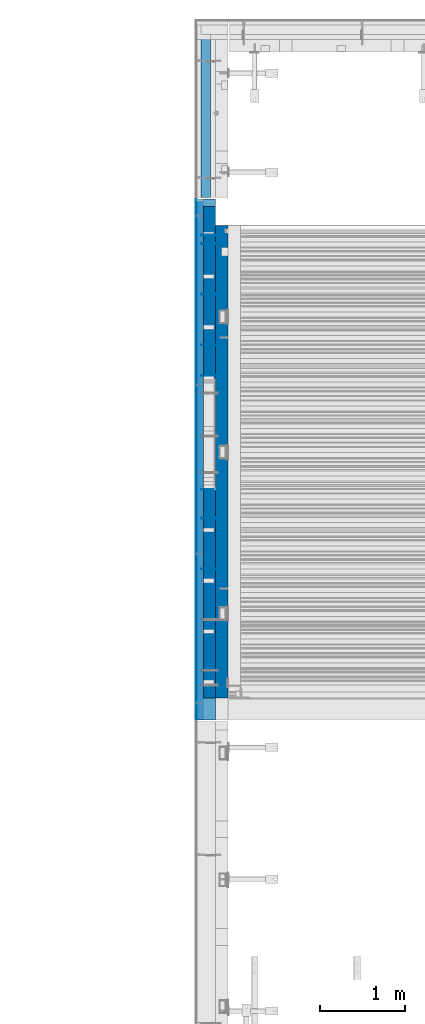
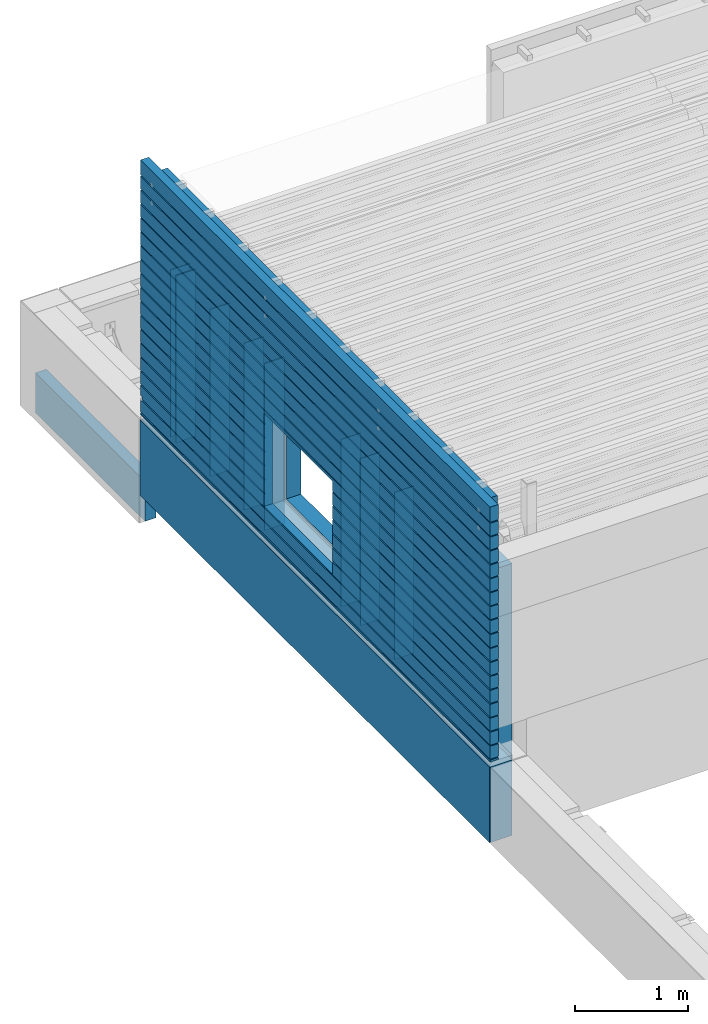
# One storey, part 78 of 153: 14 walls, 2 elements without a shape of their own.
"""IFC2X3 building model written with IfcOpenShell, lengths in millimetres."""

from ifc_helpers import new_model, si_unit, frame, origin_with_axes, place, context, subcontext, project, spatial, faceted_brep, material, type_object, element, aggregate, save


model = new_model("IFC2X3")

# Units and contexts
model_context = context("Model", 3, precision=1e-05, world=origin_with_axes())
body_context = subcontext(model_context, "Body", "Model", "MODEL_VIEW")
ifc_project = project(units=[si_unit("LENGTHUNIT", "METRE", prefix="MILLI"), si_unit("AREAUNIT", "SQUARE_METRE"), si_unit("VOLUMEUNIT", "CUBIC_METRE"), si_unit("MASSUNIT", "GRAM", prefix="KILO"), si_unit("TIMEUNIT", "SECOND"), si_unit("PLANEANGLEUNIT", "RADIAN"), si_unit("SOLIDANGLEUNIT", "STERADIAN"), si_unit("THERMODYNAMICTEMPERATUREUNIT", "DEGREE_CELSIUS"), si_unit("LUMINOUSINTENSITYUNIT", "LUMEN")], contexts=[model_context])

# Site, building, storey
site_placement = place(None, origin_with_axes())
site = spatial("IfcSite", under=ifc_project, at=site_placement, CompositionType="ELEMENT")
building_placement = place(site_placement, origin_with_axes())
building = spatial("IfcBuilding", under=site, at=building_placement, CompositionType="ELEMENT")
storey_placement = place(building_placement, origin_with_axes())
storey = spatial("IfcBuildingStorey", under=building, at=storey_placement, Name="8", CompositionType="ELEMENT", Elevation=0.0)

# Assembly, walls
assembly_1_placement = place(storey_placement, origin_with_axes())
assembly_1 = element("IfcElementAssembly", 1, at=assembly_1_placement, inside=storey, AssemblyPlace="NOTDEFINED", PredefinedType="REINFORCEMENT_UNIT")
ifc_material_1 = material(Name="Undefined")
wall_type_1 = type_object("IfcWallType", PredefinedType="NOTDEFINED")
wall_1_placement = place(assembly_1_placement, frame((7880.0, 18794.39, 104525.0), z_axis=(0.0, 0.0, 1.0), x_axis=(-1.0, 3.00000001838171e-08, 0.0)))
wall_1 = element("IfcWall", 2, at=wall_1_placement, type_object=wall_type_1, material=ifc_material_1, Name="(PD)", context=body_context, shape_type="Brep", body=[
    faceted_brep([(0.0, 5.0, -900.0), (0.0, 5.0, 900.0), (200.0, 5.0, 900.0), (200.0, 5.0, -900.0), (0.0, -5.0, 900.0), (200.0, -5.0, 900.0), (0.0, -5.0, -900.0), (200.0, -5.0, -900.0)], [[[0, 1, 2, 3]], [[1, 4, 5, 2]], [[4, 6, 7, 5]], [[6, 0, 3, 7]], [[5, 7, 3, 2]], [[6, 4, 1, 0]]]),
])
wall_2_placement = place(assembly_1_placement, frame((7880.0, 19154.39, 104525.0), z_axis=(0.0, 0.0, 1.0), x_axis=(-1.0, 3.00000001838171e-08, 0.0)))
wall_2 = element("IfcWall", 3, at=wall_2_placement, type_object=wall_type_1, material=ifc_material_1, Name="(PD)", context=body_context, shape_type="Brep", body=[
    faceted_brep([(0.0, 5.0, -900.0), (0.0, 5.0, 900.0), (200.0, 5.0, 900.0), (200.0, 5.0, -900.0), (0.0, -5.0, 900.0), (200.0, -5.0, 900.0), (0.0, -5.0, -900.0), (200.0, -5.0, -900.0)], [[[0, 1, 2, 3]], [[1, 4, 5, 2]], [[4, 6, 7, 5]], [[6, 0, 3, 7]], [[5, 7, 3, 2]], [[6, 4, 1, 0]]]),
])
wall_3_placement = place(assembly_1_placement, frame((7880.0, 19754.39, 104525.0), z_axis=(0.0, 0.0, 1.0), x_axis=(-1.0, 3.00000001838171e-08, 0.0)))
wall_3 = element("IfcWall", 4, at=wall_3_placement, type_object=wall_type_1, material=ifc_material_1, Name="(PD)", context=body_context, shape_type="Brep", body=[
    faceted_brep([(0.0, 5.0, -900.0), (0.0, 5.0, 900.0), (200.0, 5.0, 900.0), (200.0, 5.0, -900.0), (0.0, -5.0, 900.0), (200.0, -5.0, 900.0), (0.0, -5.0, -900.0), (200.0, -5.0, -900.0)], [[[0, 1, 2, 3]], [[1, 4, 5, 2]], [[4, 6, 7, 5]], [[6, 0, 3, 7]], [[5, 7, 3, 2]], [[6, 4, 1, 0]]]),
])
wall_4_placement = place(assembly_1_placement, frame((7880.0, 20454.39, 104525.0), z_axis=(0.0, 0.0, 1.0), x_axis=(-1.0, 3.00000001838171e-08, 0.0)))
wall_4 = element("IfcWall", 5, at=wall_4_placement, type_object=wall_type_1, material=ifc_material_1, Name="(PD)", context=body_context, shape_type="Brep", body=[
    faceted_brep([(0.0, 5.0, -900.0), (0.0, 5.0, 900.0), (200.0, 5.0, 900.0), (200.0, 5.0, -900.0), (0.0, -5.0, 900.0), (200.0, -5.0, 900.0), (0.0, -5.0, -900.0), (200.0, -5.0, -900.0)], [[[0, 1, 2, 3]], [[1, 4, 5, 2]], [[4, 6, 7, 5]], [[6, 0, 3, 7]], [[5, 7, 3, 2]], [[6, 4, 1, 0]]]),
])
wall_5_placement = place(assembly_1_placement, frame((7880.0, 16504.39, 104525.0), z_axis=(0.0, 0.0, 1.0), x_axis=(-1.0, 3.00000001838171e-08, 0.0)))
wall_5 = element("IfcWall", 6, at=wall_5_placement, type_object=wall_type_1, material=ifc_material_1, Name="(PD)", context=body_context, shape_type="Brep", body=[
    faceted_brep([(0.0, 5.0, -900.0), (0.0, 5.0, 900.0), (200.0, 5.0, 900.0), (200.0, 5.0, -900.0), (0.0, -5.0, 900.0), (200.0, -5.0, 900.0), (0.0, -5.0, -900.0), (200.0, -5.0, -900.0)], [[[0, 1, 2, 3]], [[1, 4, 5, 2]], [[4, 6, 7, 5]], [[6, 0, 3, 7]], [[5, 7, 3, 2]], [[6, 4, 1, 0]]]),
])
wall_6_placement = place(assembly_1_placement, frame((7880.0, 20354.39, 104525.0), z_axis=(0.0, 0.0, 1.0), x_axis=(-1.0, 3.00000001838171e-08, 0.0)))
wall_6 = element("IfcWall", 7, at=wall_6_placement, type_object=wall_type_1, material=ifc_material_1, Name="(PD)", context=body_context, shape_type="Brep", body=[
    faceted_brep([(0.0, 5.0, -900.0), (0.0, 5.0, 900.0), (200.0, 5.0, 900.0), (200.0, 5.0, -900.0), (0.0, -5.0, 900.0), (200.0, -5.0, 900.0), (0.0, -5.0, -900.0), (200.0, -5.0, -900.0)], [[[0, 1, 2, 3]], [[1, 4, 5, 2]], [[4, 6, 7, 5]], [[6, 0, 3, 7]], [[5, 7, 3, 2]], [[6, 4, 1, 0]]]),
])
wall_7_placement = place(assembly_1_placement, frame((7880.0, 17444.39, 104525.0), z_axis=(0.0, 0.0, 1.0), x_axis=(-1.0, 3.00000001838171e-08, 0.0)))
wall_7 = element("IfcWall", 8, at=wall_7_placement, type_object=wall_type_1, material=ifc_material_1, Name="(PD)", context=body_context, shape_type="Brep", body=[
    faceted_brep([(0.0, 5.0, -900.0), (0.0, 5.0, 900.0), (200.0, 5.0, 900.0), (200.0, 5.0, -900.0), (0.0, -5.0, 900.0), (200.0, -5.0, 900.0), (0.0, -5.0, -900.0), (200.0, -5.0, -900.0)], [[[0, 1, 2, 3]], [[1, 4, 5, 2]], [[4, 6, 7, 5]], [[6, 0, 3, 7]], [[5, 7, 3, 2]], [[6, 4, 1, 0]]]),
])
wall_8_placement = place(assembly_1_placement, frame((7880.0, 17104.39, 104525.0), z_axis=(0.0, 0.0, 1.0), x_axis=(-1.0, 3.00000001838171e-08, 0.0)))
wall_8 = element("IfcWall", 9, at=wall_8_placement, type_object=wall_type_1, material=ifc_material_1, Name="(PD)", context=body_context, shape_type="Brep", body=[
    faceted_brep([(0.0, 5.0, -900.0), (0.0, 5.0, 900.0), (200.0, 5.0, 900.0), (200.0, 5.0, -900.0), (0.0, -5.0, 900.0), (200.0, -5.0, 900.0), (0.0, -5.0, -900.0), (200.0, -5.0, -900.0)], [[[0, 1, 2, 3]], [[1, 4, 5, 2]], [[4, 6, 7, 5]], [[6, 0, 3, 7]], [[5, 7, 3, 2]], [[6, 4, 1, 0]]]),
])

# Assembly, wall
assembly_2_placement = place(storey_placement, origin_with_axes())
assembly_2 = element("IfcElementAssembly", 10, at=assembly_2_placement, inside=storey, AssemblyPlace="NOTDEFINED", PredefinedType="REINFORCEMENT_UNIT")
ifc_material_2 = material(Name="CONCRETE/C25/30")
wall_type_2 = type_object("IfcWallType", PredefinedType="NOTDEFINED")
wall_9_placement = place(assembly_2_placement, frame((7734.99893035865, 22830.0018973893, 102660.0), z_axis=(0.0, 0.0, 1.0), x_axis=(0.0, -1.0, 0.0)))
wall_9 = element("IfcWall", 11, at=wall_9_placement, type_object=wall_type_2, material=ifc_material_2, context=body_context, shape_type="Brep", body=[
    faceted_brep([(9.09494701772928e-13, 55.0, -215.0), (9.09494701772928e-13, 55.0, 215.0), (1930.00200932268, 55.0000000000009, 215.0), (1930.00200932268, 55.0000000000009, -215.0), (0.0, -55.0, 215.0), (1930.00200932269, -55.0, 215.0), (0.0, -55.0, -215.0), (1930.00200932269, -55.0, -215.0)], [[[0, 1, 2, 3]], [[1, 4, 5, 2]], [[4, 6, 7, 5]], [[6, 0, 3, 7]], [[5, 7, 3, 2]], [[6, 4, 1, 0]]]),
])
aggregate(assembly_2, [wall_9])

# Wall
ifc_material_3 = material()
wall_type_3 = type_object("IfcWallType", PredefinedType="NOTDEFINED")
wall_10_placement = place(assembly_1_placement, frame((7740.0, 14717.03, 103162.5), z_axis=(0.0, 0.0, 1.0), x_axis=(0.0, 1.0, 0.0)))
wall_10 = element("IfcWall", 12, at=wall_10_placement, type_object=wall_type_3, material=ifc_material_3, context=body_context, shape_type="Brep", body=[
    faceted_brep([(0.0, 110.0, -407.5), (0.0, 110.0, 407.5), (6167.97, 110.0, 407.5), (6167.97, 110.0, -407.5), (0.0, -110.0, 407.5), (6167.97, -110.0, 407.5), (0.0, -110.0, -407.5), (6167.97, -110.0, -407.5)], [[[0, 1, 2, 3]], [[1, 4, 5, 2]], [[4, 6, 7, 5]], [[6, 0, 3, 7]], [[5, 7, 3, 2]], [[6, 4, 1, 0]]]),
])

ifc_material_4 = material()
wall_type_4 = type_object("IfcWallType", PredefinedType="NOTDEFINED")
wall_11_placement = place(assembly_1_placement, frame((7625.0, 20885.0, 103162.5), z_axis=(0.0, 0.0, 1.0), x_axis=(0.0, -1.0, 0.0)))
wall_11 = element("IfcWall", 13, at=wall_11_placement, type_object=wall_type_4, material=ifc_material_4, context=body_context, shape_type="Brep", body=[
    faceted_brep([(0.0, 5.0, -407.5), (0.0, 5.0, 407.5), (6167.97, 5.0, 407.5), (6167.97, 5.0, -407.5), (0.0, -5.0, 407.5), (6167.97, -5.0, 407.5), (0.0, -5.0, -407.5), (6167.97, -5.0, -407.5)], [[[0, 1, 2, 3]], [[1, 4, 5, 2]], [[4, 6, 7, 5]], [[6, 0, 3, 7]], [[5, 7, 3, 2]], [[6, 4, 1, 0]]]),
])

wall_type_5 = type_object("IfcWallType", PredefinedType="NOTDEFINED")
wall_12_placement = place(assembly_1_placement, frame((7925.0, 14980.0, 104112.5), z_axis=(0.0, 0.0, 1.0), x_axis=(0.0, 1.0, 0.0)))
wall_12 = element("IfcWall", 14, at=wall_12_placement, type_object=wall_type_5, material=ifc_material_2, context=body_context, shape_type="Brep", body=[
    faceted_brep([(3721.24999999999, -75.0, -152.5), (3721.24999999999, 75.0, -152.5), (2521.24999999999, 75.0, -152.5), (2521.24999999999, -75.0, -152.5), (2521.24999999999, 75.0, 847.5), (2521.24999999999, -75.0, 847.5), (3721.24999999999, 75.0, 847.5), (3721.24999999999, -75.0, 847.5), (5590.0, -75.0, -1357.5), (5590.0, -75.0, 1357.5), (5565.0, -75.0000042038546, 1357.5), (5565.0, -75.0, -1357.5), (5590.0, 75.0, 1357.5), (0.0, 75.0, 1357.5), (0.0, -75.0, 1357.5), (5485.0, -75.0, 1357.5), (5505.0, -55.0000042038546, 1357.5), (5545.0, -55.0000042038546, 1357.5), (0.0, -75.0, -1357.5), (0.0, 75.0, -1357.5), (5485.0, -75.0, -1357.5), (5505.0, -55.0000042038546, -1357.5), (5545.0, -55.0000042038546, -1357.5), (5590.0, 75.0, -1357.5)], [[[0, 1, 2, 3]], [[3, 2, 4, 5]], [[5, 4, 6, 7]], [[7, 6, 1, 0]], [[8, 9, 10, 11]], [[9, 12, 13, 14, 15, 16, 17, 10]], [[18, 14, 13, 19]], [[14, 18, 20, 15], [3, 5, 7, 0]], [[15, 20, 21, 16]], [[16, 21, 22, 17]], [[10, 17, 22, 11]], [[21, 20, 18, 19, 23, 8, 11, 22]], [[9, 8, 23, 12]], [[19, 13, 12, 23], [2, 1, 6, 4]]]),
])

ifc_material_5 = material(Name="CONCRETE/C30/37")
wall_type_6 = type_object("IfcWallType", PredefinedType="NOTDEFINED")
wall_13_placement = place(assembly_1_placement, frame((7667.5, 14720.0, 104992.5), z_axis=(0.0, 0.0, 1.0), x_axis=(0.0, 1.0, 0.0)))
wall_13 = element("IfcWall", 15, at=wall_13_placement, type_object=wall_type_6, material=ifc_material_5, context=body_context, shape_type="Brep", body=[
    faceted_brep([(6164.99999924241, -42.5, -1038.00000011075), (6165.0, 42.5, -1038.00000011075), (6165.0, 42.5, -902.000000055239), (6164.99999928515, -42.5, -902.000000055239), (6164.99999924241, -42.5, -888.000000110755), (6165.0, 42.5, -888.000000110755), (6165.0, 42.5, -752.000000055239), (6164.99999928799, -42.5, -752.000000055239), (6154.99999924993, 32.499999249937, -750.000000000786), (6154.99999924993, -42.5, -750.0000000008), (6154.99999911194, 32.4999991119366, -739.999999599575), (6154.99999911194, -42.5, -739.999999599575), (6164.99999924241, -42.5, -738.000000110755), (6165.0, 42.5, -738.000000110755), (6165.0, 42.5, -602.000000055239), (6164.99999929122, -42.5, -602.000000055239), (6154.99999924993, 32.499999249937, -600.000000000786), (6154.99999924993, -42.5, -600.0000000008), (6154.99999911194, 32.4999991119366, -589.999999599575), (6154.99999911194, -42.5, -589.999999599575), (6164.99999924241, -42.5, -588.000000110755), (6165.0, 42.5, -588.000000110755), (6165.0, 42.5, -452.000000055239), (6164.99999929496, -42.5, -452.000000055239), (6154.99999924993, 32.499999249937, -450.000000000786), (6154.99999924993, -42.5, -450.0000000008), (6154.99999911194, 32.4999991119366, -439.999999599575), (6154.99999911194, -42.5, -439.999999599575), (6164.99999924241, -42.5, -438.000000110755), (6165.0, 42.5, -438.000000110755), (6165.0, 42.5, -302.000000055239), (6164.99999929931, -42.5, -302.000000055239), (6154.99999924993, 32.499999249937, -300.000000000786), (6154.99999924993, -42.5, -300.0000000008), (6154.99999911194, 32.4999991119366, -289.999999599575), (6154.99999911194, -42.5, -289.999999599575), (6164.99999924241, -42.5, -288.000000110755), (6165.0, 42.5, -288.000000110755), (6165.0, 42.5, -152.000000055239), (6164.99999930445, -42.5, -152.000000055239), (6154.99999924993, 32.499999249937, -150.000000000786), (6154.99999924993, -42.5, -150.0000000008), (6154.99999911194, 32.4999991119366, -139.999999599575), (6154.99999911194, -42.5, -139.999999599575), (6164.99999924241, -42.5, -138.000000110755), (6165.0, 42.5, -138.000000110755), (6165.0, 42.5, -2.00000005523907), (6164.99999931062, -42.5, -2.00000005523907), (6164.99999924241, -42.5, 11.9999998892454), (6165.0, 42.5, 11.9999998892454), (6165.0, 42.5, 147.999999944761), (6164.99999931814, -42.5, 147.999999944761), (6154.99999924993, 32.499999249937, 149.999999999214), (6154.99999924993, -42.5, 149.9999999992), (6164.99999924241, -42.5, 161.999999889245), (6165.0, 42.5, 161.999999889245), (6165.0, 42.5, 297.999999944761), (6164.99999932752, -42.5, 297.999999944761), (6154.99999924993, 32.499999249937, 299.999999999214), (6154.99999924993, -42.5, 299.9999999992), (6164.99999924241, -42.5, 311.999999889245), (6165.0, 42.5, 311.999999889245), (6165.0, 42.5, 447.999999944761), (6164.99999933956, -42.5, 447.999999944761), (6154.99999924993, 32.499999249937, 449.999999999214), (6154.99999924993, -42.5, 449.9999999992), (6164.99999924241, -42.5, 461.999999889245), (6165.0, 42.5, 461.999999889245), (6165.0, 42.5, 597.999999944761), (6164.99999935556, -42.5, 597.999999944761), (6154.99999924993, 32.499999249937, 599.999999999214), (6154.99999924993, -42.5, 599.9999999992), (6164.99999924241, -42.5, 611.999999889245), (6165.0, 42.5, 611.999999889245), (6165.0, 42.5, 747.999999944761), (6164.99999937789, -42.5, 747.999999944761), (6154.99999924993, 32.499999249937, 749.999999999214), (6154.99999924993, -42.5, 749.9999999992), (6164.99999924241, -42.5, 761.999999889245), (6165.0, 42.5, 761.999999889245), (6165.0, 42.5, 897.999999944761), (6164.99999941117, -42.5, 897.999999944761), (6154.99999924993, 32.499999249937, 899.999999999214), (6154.99999924993, -42.5, 899.9999999992), (6164.99999924241, -42.5, 911.999999889245), (6165.0, 42.5, 911.999999889245), (6165.0, 42.5, 1047.99999994476), (6164.99999946615, -42.5, 1047.99999994476), (6154.99999924993, 32.499999249937, 1049.99999999921), (6154.99999924993, -42.5, 1049.9999999992), (6164.99999924241, -42.5, 1061.99999988925), (6165.0, 42.5, 1061.99999988925), (6165.0, 42.5, 1197.99999994476), (6164.99999957423, -42.5, 1197.99999994476), (6154.99999924993, 32.499999249937, 1199.99999999921), (6154.99999924993, -42.5, 1199.9999999992), (0.0, 42.5, 1372.5), (0.0, -42.5, 1372.5), (6165.0, -42.5, 1372.5), (6165.0, 42.5, 1372.5), (6164.99999924241, -42.5, 1211.99999988925), (6165.0, 42.5, 1211.99999988925), (0.0, 42.5, 1211.99999988925), (0.0, -42.5, 1211.99999988925), (10.0000008880688, 32.4999991119366, 1210.00000040043), (10.0000008880688, -42.5000000000027, 1210.00000040043), (6154.99999911194, 32.4999991119366, 1210.00000040043), (6154.99999911194, -42.5, 1210.00000040043), (10.0000007500657, 32.499999249937, 1199.99999999921), (10.0000007500657, -42.5000000000027, 1199.9999999992), (0.0, 42.5, 1197.99999994476), (0.0, -42.5, 1197.99999994476), (0.0, 42.5, 1061.99999988925), (0.0, -42.5, 1061.99999988925), (10.0000008880688, 32.4999991119366, 1060.00000040043), (10.0000008880688, -42.5000000000009, 1060.00000040043), (6154.99999911194, 32.4999991119366, 1060.00000040043), (6154.99999911194, -42.5, 1060.00000040043), (10.0000007500657, 32.499999249937, 1049.99999999921), (10.0000007500657, -42.5000000000009, 1049.9999999992), (0.0, 42.5, 1047.99999994476), (0.0, -42.5, 1047.99999994476), (0.0, 42.5, 911.999999889245), (0.0, -42.5, 911.999999889245), (10.0000008880688, 32.4999991119366, 910.000000400425), (10.0000008880688, -42.5000000000009, 910.000000400425), (6154.99999911194, 32.4999991119366, 910.000000400425), (6154.99999911194, -42.5, 910.000000400425), (10.0000007500657, 32.499999249937, 899.999999999214), (10.0000007500657, -42.5000000000009, 899.9999999992), (0.0, 42.5, 897.999999944761), (0.0, -42.5, 897.999999944761), (0.0, 42.5, 761.999999889245), (0.0, -42.5, 761.999999889245), (10.0000008880688, 32.4999991119366, 760.000000400425), (10.0000008880688, -42.5000000000009, 760.000000400425), (6154.99999911194, 32.4999991119366, 760.000000400425), (6154.99999911194, -42.5, 760.000000400425), (10.0000007500657, 32.499999249937, 749.999999999214), (10.0000007500657, -42.5000000000009, 749.9999999992), (0.0, 42.5, 747.999999944761), (0.0, -42.5, 747.999999944761), (0.0, 42.5, 611.999999889245), (0.0, -42.5, 611.999999889245), (10.0000008880688, 32.4999991119366, 610.000000400425), (10.0000008880688, -42.5, 610.000000400425), (6154.99999911194, 32.4999991119366, 610.000000400425), (6154.99999911194, -42.5, 610.000000400425), (10.0000007500657, 32.499999249937, 599.999999999214), (10.0000007500657, -42.5, 599.9999999992), (0.0, 42.5, 597.999999944761), (0.0, -42.5, 597.999999944761), (0.0, 42.5, 461.999999889245), (0.0, -42.5, 461.999999889245), (10.0000008880688, 32.4999991119366, 460.000000400425), (10.0000008880688, -42.5, 460.000000400425), (6154.99999911194, 32.4999991119366, 460.000000400425), (6154.99999911194, -42.5, 460.000000400425), (10.0000007500657, 32.499999249937, 449.999999999214), (10.0000007500657, -42.5, 449.9999999992), (0.0, 42.5, 447.999999944761), (0.0, -42.5, 447.999999944761), (0.0, 42.5, 311.999999889245), (0.0, -42.5, 311.999999889245), (10.0000008880688, 32.4999991119366, 310.000000400425), (10.0000008880688, -42.5, 310.000000400425), (6154.99999911194, 32.4999991119366, 310.000000400425), (6154.99999911194, -42.5, 310.000000400425), (10.0000007500657, 32.499999249937, 299.999999999214), (10.0000007500657, -42.5, 299.9999999992), (0.0, 42.5, 297.999999944761), (0.0, -42.5, 297.999999944761), (0.0, 42.5, 161.999999889245), (0.0, -42.5, 161.999999889245), (10.0000008880688, 32.4999991119366, 160.000000400425), (10.0000008880688, -42.5, 160.000000400425), (6154.99999911194, 32.4999991119366, 160.000000400425), (6154.99999911194, -42.5, 160.000000400425), (10.0000007500657, 32.499999249937, 149.999999999214), (10.0000007500657, -42.5, 149.9999999992), (0.0, 42.5, 147.999999944761), (0.0, -42.5, 147.999999944761), (0.0, 42.5, 11.9999998892454), (0.0, -42.5, 11.9999998892454), (6154.99999911194, 32.4999991119366, 10.0000004004251), (6154.99999924993, 32.499999249937, -7.8580342233181e-10), (10.0000007500657, 32.499999249937, -7.8580342233181e-10), (10.0000008880688, 32.4999991119366, 10.0000004004251), (10.0000008880688, -42.5, 10.0000004004251), (10.0000007500657, -42.5, -8.00355337560177e-10), (6154.99999911194, -42.5, 10.0000004004251), (6154.99999924993, -42.5, -8.00355337560177e-10), (0.0, 42.5, -2.00000005523907), (0.0, -42.5, -2.00000005523907), (0.0, 42.5, -138.000000110755), (0.0, -42.5, -138.000000110755), (10.0000008880688, 32.4999991119366, -139.999999599575), (10.0000008880688, -42.5, -139.999999599575), (10.0000007500657, 32.499999249937, -150.000000000786), (10.0000007500657, -42.5, -150.0000000008), (0.0, 42.5, -152.000000055239), (0.0, -42.5, -152.000000055239), (0.0, 42.5, -288.000000110755), (0.0, -42.5, -288.000000110755), (10.0000008880688, 32.4999991119366, -289.999999599575), (10.0000008880688, -42.5, -289.999999599575), (10.0000007500657, 32.499999249937, -300.000000000786), (10.0000007500657, -42.5, -300.0000000008), (0.0, 42.5, -302.000000055239), (0.0, -42.5, -302.000000055239), (0.0, 42.5, -438.000000110755), (0.0, -42.5, -438.000000110755), (10.0000008880688, 32.4999991119366, -439.999999599575), (10.0000008880688, -42.5, -439.999999599575), (10.0000007500657, 32.499999249937, -450.000000000786), (10.0000007500657, -42.5, -450.0000000008), (0.0, 42.5, -452.000000055239), (0.0, -42.5, -452.000000055239), (0.0, 42.5, -588.000000110755), (0.0, -42.5, -588.000000110755), (10.0000008880688, 32.4999991119366, -589.999999599575), (10.0000008880688, -42.5, -589.999999599575), (10.0000007500657, 32.499999249937, -600.000000000786), (10.0000007500657, -42.5, -600.0000000008), (0.0, 42.5, -602.000000055239), (0.0, -42.5, -602.000000055239), (0.0, 42.5, -738.000000110755), (0.0, -42.5, -738.000000110755), (10.0000008880688, 32.4999991119366, -739.999999599575), (10.0000008880688, -42.5, -739.999999599575), (10.0000007500657, 32.499999249937, -750.000000000786), (10.0000007500657, -42.5, -750.0000000008), (0.0, 42.5, -752.000000055239), (0.0, -42.5, -752.000000055239), (0.0, 42.5, -888.000000110755), (0.0, -42.5, -888.000000110755), (10.0000008880688, 32.4999991119366, -889.999999599575), (10.0000008880688, -42.5, -889.999999599575), (10.0000007500657, 32.499999249937, -900.000000000786), (10.0000007500657, -42.5, -900.0000000008), (0.0, 42.5, -902.000000055239), (0.0, -42.5, -902.000000055239), (0.0, 42.5, -1038.00000011075), (0.0, -42.5, -1038.00000011075), (6154.99999911194, 32.4999991119366, -1039.99999959957), (6154.99999924993, 32.499999249937, -1050.00000000079), (10.0000007500657, 32.499999249937, -1050.00000000079), (10.0000008880688, 32.4999991119366, -1039.99999959957), (6165.0, 42.5, -1052.00000005524), (0.0, 42.5, -1052.00000005524), (6134.99999999999, 42.5, -1188.00000011075), (6134.99999999999, 32.4999991119366, -1189.99999959957), (10.0000008880688, 32.4999991119366, -1189.99999959957), (0.0, 42.5, -1188.00000011075), (6134.99999999999, 32.499999249937, -1200.00000000079), (10.0000007500639, 32.499999249937, -1200.00000000079), (6134.99999999999, 42.5, -1202.00000005524), (0.0, 42.5, -1202.00000005524), (6165.0, 42.5, -1338.00000011075), (0.0, 42.5, -1338.00000011075), (6134.99999999999, 42.4999999999927, -1212.50000011071), (6165.0, 42.5, -1212.50000011071), (6165.0, 42.5, -1372.5), (0.0, 42.5, -1372.5), (0.0, 42.5, -1352.00000005524), (6165.0, 42.5, -1352.00000005524), (6165.0, 32.499999249937, -1350.00000000079), (10.0000007500657, 32.499999249937, -1350.00000000079), (6165.0, 32.4999991119366, -1339.99999959957), (10.0000008880688, 32.4999991119366, -1339.99999959957), (0.0, -42.5, -1338.00000011075), (10.0000008880688, -42.5000000000009, -1339.99999959957), (0.0, -42.5, -1202.00000005524), (10.0000007500657, -42.5, -1200.0000000008), (10.0000008880688, -42.5, -1189.99999959957), (0.0, -42.5, -1188.00000011075), (0.0, -42.5, -1052.00000005524), (10.0000007500657, -42.5, -1050.0000000008), (10.0000008880688, -42.5, -1039.99999959957), (6154.99999911194, -42.5, -1039.99999959957), (6154.99999924993, -42.5, -1050.0000000008), (6165.0, -42.5, -1052.00000005524), (6164.99999999999, -42.5, -1162.50000011071), (6165.0, 42.5, -1162.50000011071), (6134.99999999999, 42.4999999999927, -1162.50000011071), (6134.99999999999, -42.5000000000009, -1162.50000011071), (6134.99999999999, -42.5000000000009, -1212.50000011071), (6165.0, -42.5, -1212.50000011071), (6165.0, -42.5, -1372.5), (0.0, -42.5, -1372.5), (0.0, -42.5, -1352.00000005524), (10.0000007500657, -42.5000000000009, -1350.0000000008), (6154.99999924993, -42.5, -900.0000000008), (6154.99999911194, -42.5, -889.999999599575), (2781.24999999999, -42.5, -1032.5), (2781.24999999999, -42.5, -32.5), (3981.24999999999, -42.5, -32.5), (3981.24999999999, -42.5, -1032.5), (6154.99999911194, 32.4999991119366, -889.999999599575), (6154.99999924993, 32.499999249937, -900.000000000786), (3981.24999999999, 42.5, -902.000000055239), (3981.24999999999, 32.499999249937, -900.000000000786), (3981.24999999999, 32.4999991119366, -889.999999599575), (3981.24999999999, 42.5, -888.000000110755), (3981.24999999999, 42.5, -752.000000055239), (3981.24999999999, 32.499999249937, -750.000000000786), (3981.24999999999, 32.4999991119366, -739.999999599575), (3981.24999999999, 42.5, -738.000000110755), (3981.24999999999, 42.5, -602.000000055239), (3981.24999999999, 32.499999249937, -600.000000000786), (3981.24999999999, 32.4999991119366, -589.999999599575), (3981.24999999999, 42.5, -588.000000110755), (3981.24999999999, 42.5, -452.000000055239), (3981.24999999999, 32.499999249937, -450.000000000786), (3981.24999999999, 32.4999991119366, -439.999999599575), (3981.24999999999, 42.5, -438.000000110755), (3981.24999999999, 42.5, -302.000000055239), (3981.24999999999, 32.499999249937, -300.000000000786), (3981.24999999999, 32.4999991119366, -289.999999599575), (3981.24999999999, 42.5, -288.000000110755), (3981.24999999999, 42.5, -152.000000055239), (3981.24999999999, 32.499999249937, -150.000000000786), (3981.24999999999, 32.4999991119366, -139.999999599575), (3981.24999999999, 42.5, -138.000000110755), (2781.24999999999, 42.5, -138.000000110755), (3981.24999999999, 42.5, -32.5), (2781.24999999999, 42.5, -32.5), (2781.24999999999, 32.4999991119366, -139.999999599575), (2781.24999999999, 32.499999249937, -150.000000000786), (2781.24999999999, 42.5, -152.000000055239), (2781.24999999999, 42.5, -288.000000110755), (2781.24999999999, 32.4999991119366, -289.999999599575), (2781.24999999999, 32.499999249937, -300.000000000786), (2781.24999999999, 42.5, -302.000000055239), (2781.24999999999, 42.5, -438.000000110755), (2781.24999999999, 32.4999991119366, -439.999999599575), (2781.24999999999, 32.499999249937, -450.000000000786), (2781.24999999999, 42.5, -452.000000055239), (2781.24999999999, 42.5, -588.000000110755), (2781.24999999999, 32.4999991119366, -589.999999599575), (2781.24999999999, 32.499999249937, -600.000000000786), (2781.24999999999, 42.5, -602.000000055239), (2781.24999999999, 42.5, -738.000000110755), (2781.24999999999, 32.4999991119366, -739.999999599575), (2781.24999999999, 32.499999249937, -750.000000000786), (2781.24999999999, 42.5, -752.000000055239), (2781.24999999999, 42.5, -888.000000110755), (2781.24999999999, 32.4999991119366, -889.999999599575), (2781.24999999999, 32.499999249937, -900.000000000786), (2781.24999999999, 42.5, -902.000000055239), (2781.24999999999, 42.5, -1032.5), (3981.24999999999, 42.5, -1032.5)], [[[0, 1, 2, 3]], [[4, 5, 6, 7]], [[7, 6, 8, 9]], [[9, 8, 10, 11]], [[12, 11, 10, 13]], [[12, 13, 14, 15]], [[15, 14, 16, 17]], [[17, 16, 18, 19]], [[20, 19, 18, 21]], [[20, 21, 22, 23]], [[23, 22, 24, 25]], [[25, 24, 26, 27]], [[28, 27, 26, 29]], [[28, 29, 30, 31]], [[31, 30, 32, 33]], [[33, 32, 34, 35]], [[36, 35, 34, 37]], [[36, 37, 38, 39]], [[39, 38, 40, 41]], [[41, 40, 42, 43]], [[44, 43, 42, 45]], [[44, 45, 46, 47]], [[48, 49, 50, 51]], [[51, 50, 52, 53]], [[54, 55, 56, 57]], [[57, 56, 58, 59]], [[60, 61, 62, 63]], [[63, 62, 64, 65]], [[66, 67, 68, 69]], [[69, 68, 70, 71]], [[72, 73, 74, 75]], [[75, 74, 76, 77]], [[78, 79, 80, 81]], [[81, 80, 82, 83]], [[84, 85, 86, 87]], [[87, 86, 88, 89]], [[90, 91, 92, 93]], [[93, 92, 94, 95]], [[96, 97, 98, 99]], [[99, 98, 100, 101]], [[96, 99, 101, 102]], [[97, 96, 102, 103]], [[103, 102, 104, 105]], [[101, 106, 104, 102]], [[100, 107, 106, 101]], [[95, 94, 106, 107]], [[106, 94, 108, 104]], [[105, 104, 108, 109]], [[109, 108, 110, 111]], [[94, 92, 110, 108]], [[91, 112, 110, 92]], [[111, 110, 112, 113]], [[113, 112, 114, 115]], [[91, 116, 114, 112]], [[90, 117, 116, 91]], [[89, 88, 116, 117]], [[116, 88, 118, 114]], [[115, 114, 118, 119]], [[119, 118, 120, 121]], [[88, 86, 120, 118]], [[85, 122, 120, 86]], [[121, 120, 122, 123]], [[123, 122, 124, 125]], [[85, 126, 124, 122]], [[84, 127, 126, 85]], [[83, 82, 126, 127]], [[126, 82, 128, 124]], [[125, 124, 128, 129]], [[129, 128, 130, 131]], [[82, 80, 130, 128]], [[79, 132, 130, 80]], [[131, 130, 132, 133]], [[133, 132, 134, 135]], [[79, 136, 134, 132]], [[78, 137, 136, 79]], [[77, 76, 136, 137]], [[136, 76, 138, 134]], [[135, 134, 138, 139]], [[139, 138, 140, 141]], [[76, 74, 140, 138]], [[73, 142, 140, 74]], [[141, 140, 142, 143]], [[143, 142, 144, 145]], [[73, 146, 144, 142]], [[72, 147, 146, 73]], [[71, 70, 146, 147]], [[146, 70, 148, 144]], [[145, 144, 148, 149]], [[149, 148, 150, 151]], [[70, 68, 150, 148]], [[67, 152, 150, 68]], [[151, 150, 152, 153]], [[153, 152, 154, 155]], [[67, 156, 154, 152]], [[66, 157, 156, 67]], [[65, 64, 156, 157]], [[156, 64, 158, 154]], [[155, 154, 158, 159]], [[159, 158, 160, 161]], [[64, 62, 160, 158]], [[61, 162, 160, 62]], [[161, 160, 162, 163]], [[163, 162, 164, 165]], [[61, 166, 164, 162]], [[60, 167, 166, 61]], [[59, 58, 166, 167]], [[166, 58, 168, 164]], [[165, 164, 168, 169]], [[169, 168, 170, 171]], [[58, 56, 170, 168]], [[55, 172, 170, 56]], [[171, 170, 172, 173]], [[173, 172, 174, 175]], [[55, 176, 174, 172]], [[54, 177, 176, 55]], [[53, 52, 176, 177]], [[176, 52, 178, 174]], [[175, 174, 178, 179]], [[179, 178, 180, 181]], [[52, 50, 180, 178]], [[49, 182, 180, 50]], [[181, 180, 182, 183]], [[184, 185, 186, 187]], [[188, 187, 186, 189]], [[183, 182, 187, 188]], [[49, 184, 187, 182]], [[48, 190, 184, 49]], [[191, 185, 184, 190]], [[47, 46, 185, 191]], [[185, 46, 192, 186]], [[189, 186, 192, 193]], [[193, 192, 194, 195]], [[195, 194, 196, 197]], [[197, 196, 198, 199]], [[199, 198, 200, 201]], [[201, 200, 202, 203]], [[203, 202, 204, 205]], [[205, 204, 206, 207]], [[207, 206, 208, 209]], [[209, 208, 210, 211]], [[211, 210, 212, 213]], [[213, 212, 214, 215]], [[215, 214, 216, 217]], [[217, 216, 218, 219]], [[219, 218, 220, 221]], [[221, 220, 222, 223]], [[223, 222, 224, 225]], [[225, 224, 226, 227]], [[227, 226, 228, 229]], [[229, 228, 230, 231]], [[231, 230, 232, 233]], [[233, 232, 234, 235]], [[235, 234, 236, 237]], [[237, 236, 238, 239]], [[239, 238, 240, 241]], [[241, 240, 242, 243]], [[244, 245, 246, 247]], [[245, 248, 249, 246]], [[250, 251, 252, 253]], [[251, 254, 255, 252]], [[254, 256, 257, 255]], [[258, 259, 257, 256, 260, 261]], [[262, 263, 264, 265]], [[266, 265, 264, 267]], [[268, 266, 267, 269]], [[258, 268, 269, 259]], [[270, 259, 269, 271]], [[272, 257, 259, 270]], [[273, 255, 257, 272]], [[274, 252, 255, 273]], [[275, 253, 252, 274]], [[276, 249, 253, 275]], [[277, 246, 249, 276]], [[278, 247, 246, 277]], [[243, 242, 247, 278]], [[1, 244, 247, 242]], [[0, 279, 244, 1]], [[280, 245, 244, 279]], [[281, 248, 245, 280]], [[248, 281, 282, 283]], [[250, 253, 249, 248, 283, 284]], [[282, 285, 284, 283]], [[286, 260, 256, 254, 251, 250, 284, 285]], [[287, 261, 260, 286]], [[288, 262, 265, 266, 268, 258, 261, 287]], [[289, 263, 262, 288]], [[263, 289, 290, 264]], [[291, 267, 264, 290]], [[271, 269, 267, 291]], [[290, 289, 288, 287, 286, 285, 282, 281, 280, 279, 0, 3, 292, 293, 4, 7, 9, 11, 12, 15, 17, 19, 20, 23, 25, 27, 28, 31, 33, 35, 36, 39, 41, 43, 44, 47, 191, 190, 48, 51, 53, 177, 54, 57, 59, 167, 60, 63, 65, 157, 66, 69, 71, 147, 72, 75, 77, 137, 78, 81, 83, 127, 84, 87, 89, 117, 90, 93, 95, 107, 100, 98, 97, 103, 105, 109, 111, 113, 115, 119, 121, 123, 125, 129, 131, 133, 135, 139, 141, 143, 145, 149, 151, 153, 155, 159, 161, 163, 165, 169, 171, 173, 175, 179, 181, 183, 188, 189, 193, 195, 197, 199, 201, 203, 205, 207, 209, 211, 213, 215, 217, 219, 221, 223, 225, 227, 229, 231, 233, 235, 237, 239, 241, 243, 278, 277, 276, 275, 274, 273, 272, 270, 271, 291], [294, 295, 296, 297]], [[4, 293, 298, 5]], [[292, 299, 298, 293]], [[3, 2, 299, 292]], [[299, 2, 300, 301]], [[298, 299, 301, 302]], [[5, 298, 302, 303]], [[6, 5, 303, 304]], [[8, 6, 304, 305]], [[10, 8, 305, 306]], [[13, 10, 306, 307]], [[14, 13, 307, 308]], [[16, 14, 308, 309]], [[18, 16, 309, 310]], [[21, 18, 310, 311]], [[22, 21, 311, 312]], [[24, 22, 312, 313]], [[26, 24, 313, 314]], [[29, 26, 314, 315]], [[30, 29, 315, 316]], [[32, 30, 316, 317]], [[34, 32, 317, 318]], [[37, 34, 318, 319]], [[38, 37, 319, 320]], [[40, 38, 320, 321]], [[42, 40, 321, 322]], [[45, 42, 322, 323]], [[324, 194, 192, 46, 45, 323, 325, 326]], [[196, 194, 324, 327]], [[198, 196, 327, 328]], [[200, 198, 328, 329]], [[202, 200, 329, 330]], [[204, 202, 330, 331]], [[206, 204, 331, 332]], [[208, 206, 332, 333]], [[210, 208, 333, 334]], [[212, 210, 334, 335]], [[214, 212, 335, 336]], [[216, 214, 336, 337]], [[218, 216, 337, 338]], [[220, 218, 338, 339]], [[222, 220, 339, 340]], [[224, 222, 340, 341]], [[226, 224, 341, 342]], [[228, 226, 342, 343]], [[230, 228, 343, 344]], [[232, 230, 344, 345]], [[234, 232, 345, 346]], [[236, 234, 346, 347]], [[238, 236, 347, 348]], [[240, 238, 348, 349]], [[2, 1, 242, 240, 349, 350, 351, 300]], [[296, 325, 323, 322, 321, 320, 319, 318, 317, 316, 315, 314, 313, 312, 311, 310, 309, 308, 307, 306, 305, 304, 303, 302, 301, 300, 351, 297]], [[295, 326, 325, 296]], [[294, 350, 349, 348, 347, 346, 345, 344, 343, 342, 341, 340, 339, 338, 337, 336, 335, 334, 333, 332, 331, 330, 329, 328, 327, 324, 326, 295]], [[297, 351, 350, 294]]]),
])

ifc_material_6 = material(Name="SPU")
wall_type_7 = type_object("IfcWallType", PredefinedType="NOTDEFINED")
wall_14_placement = place(assembly_1_placement, frame((7780.0, 14980.0, 104937.5), z_axis=(0.0, 0.0, 1.0), x_axis=(0.0, 1.0, 0.0)))
wall_14 = element("IfcWall", 16, at=wall_14_placement, type_object=wall_type_7, material=ifc_material_6, context=body_context, shape_type="Brep", body=[
    faceted_brep([(0.0, -70.0, 1317.5), (0.0, -70.0, -1317.5), (5815.0, -70.0, -1317.5), (5815.0, -70.0, 1317.5), (2471.24999999999, -70.0, -1027.5), (2471.24999999999, -70.0, 72.5), (3771.24999999999, -70.0, 72.5), (3771.24999999999, -70.0, -1027.5), (0.0, 70.0, 1317.5), (5815.0, 70.0, 1317.5), (0.0, 70.0, -1317.5), (5815.0, 70.0, -1317.5), (2471.24999999999, 70.0, -1027.5), (3771.24999999999, 70.0, -1027.5), (3771.24999999999, 70.0, 72.5), (2471.24999999999, 70.0, 72.5)], [[[0, 1, 2, 3], [4, 5, 6, 7]], [[8, 0, 3, 9]], [[1, 0, 8, 10]], [[1, 10, 11, 2]], [[3, 2, 11, 9]], [[10, 8, 9, 11], [12, 13, 14, 15]], [[6, 14, 13, 7]], [[5, 15, 14, 6]], [[4, 12, 15, 5]], [[7, 13, 12, 4]]]),
])

aggregate(assembly_1, [wall_1, wall_2, wall_3, wall_4, wall_5, wall_6, wall_7, wall_8, wall_10, wall_11, wall_13, wall_14, wall_12])

save(model, "model.ifc")
